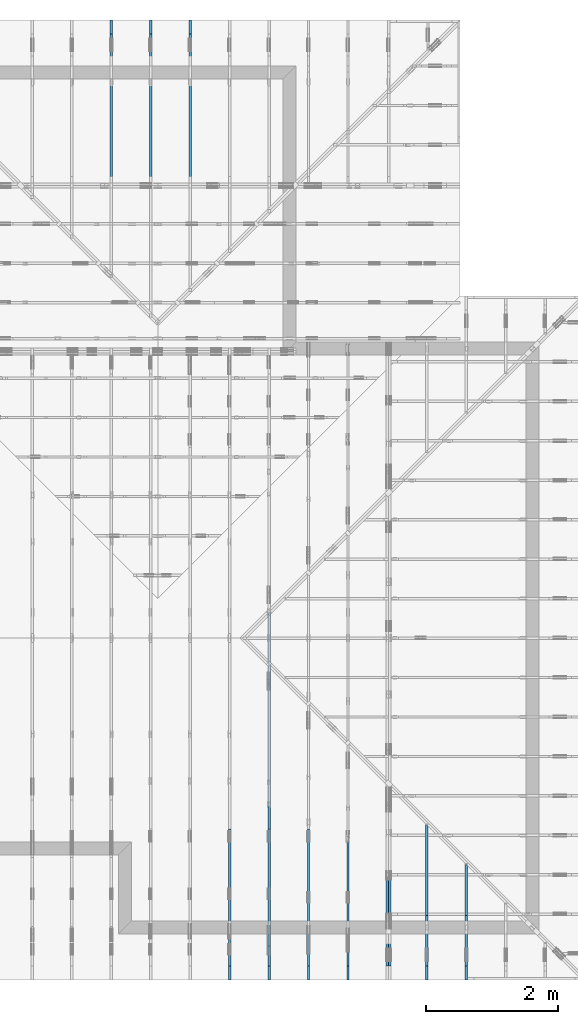
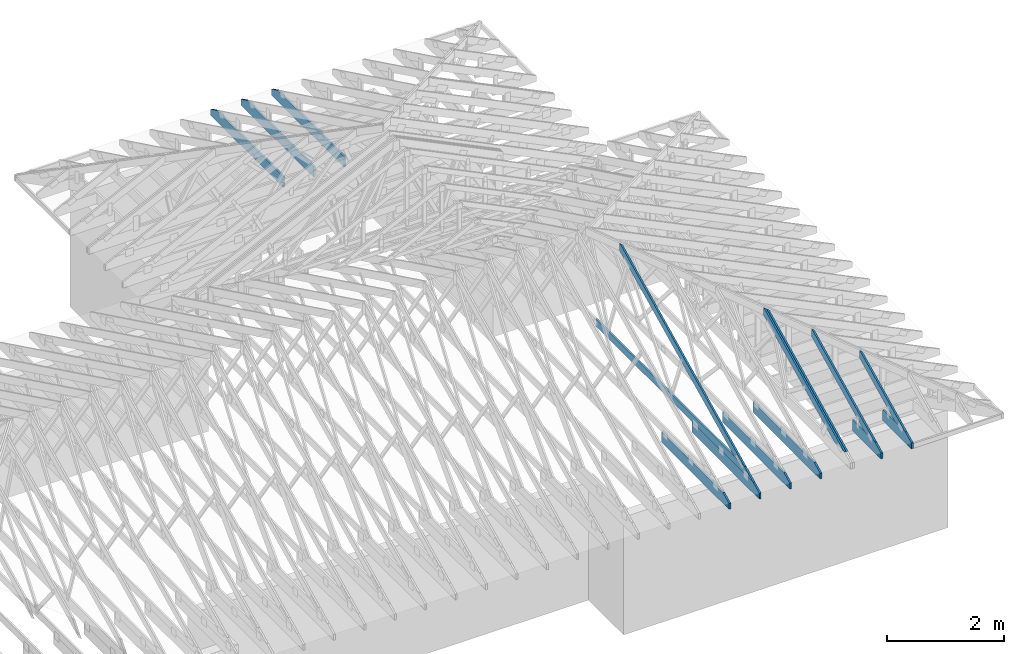
# One storey, part 28 of 159: 15 members, 10 elements without a shape of their own.
"""IFC2X3 building model written with IfcOpenShell, lengths in millimetres."""

from ifc_helpers import new_model, si_unit, frame, origin, origin_with_axes, origin_2d, place, context, project, spatial, faceted_brep, element, aggregate, save


model = new_model("IFC2X3")

# Units and contexts
model_context = context("Model", 3, precision=1e-05, world=origin())
plan_context = context("Plan", 2, precision=1e-05, world=origin_2d())
ifc_project = project(units=[si_unit("LENGTHUNIT", "METRE", prefix="MILLI"), si_unit("AREAUNIT", "SQUARE_METRE"), si_unit("VOLUMEUNIT", "CUBIC_METRE"), si_unit("SOLIDANGLEUNIT", "STERADIAN"), si_unit("PLANEANGLEUNIT", "RADIAN"), si_unit("MASSUNIT", "GRAM"), si_unit("TIMEUNIT", "SECOND"), si_unit("THERMODYNAMICTEMPERATUREUNIT", "DEGREE_CELSIUS"), si_unit("LUMINOUSINTENSITYUNIT", "LUMEN")], contexts=[model_context, plan_context])

# Site, building, storey
site_placement = place(None, origin_with_axes())
site = spatial("IfcSite", under=ifc_project, at=site_placement, CompositionType="ELEMENT")
building_placement = place(site_placement, origin_with_axes())
building = spatial("IfcBuilding", under=site, at=building_placement, Name="Plan 1", CompositionType="ELEMENT")
storey_placement = place(building_placement, origin_with_axes())
storey = spatial("IfcBuildingStorey", under=building, at=storey_placement, Name="Etasje 1", CompositionType="ELEMENT", Elevation=0.0)

# Assembly, members
assembly_1_placement = place(storey_placement, frame((16311.022261404749, -699.9989301294839, 1.1021457184401395e-15), z_axis=(1.0, -6.123031769111886e-17, 6.123031769111886e-17), x_axis=(6.123031769111886e-17, 1.0, 0.0)))
assembly_1 = element("IfcElementAssembly", 1, at=assembly_1_placement, inside=storey, Name="V8 (33)", AssemblyPlace="FACTORY", PredefinedType="TRUSS")
member_1_placement = place(assembly_1_placement, frame((579.5050728037174, 237.97842169881216, -36.00000021823818), z_axis=(0.0, 0.0, 1.0), x_axis=(0.898794046299167, 0.4383711467890774, 0.0)))
member_1 = element("IfcMember", 2, at=member_1_placement, Name="V8-O12", context=model_context, shape_type="Brep", body=[
    faceted_brep([(4739.075193296503, 148.00000083133853, 2.2545041247212794e-06), (4699.021526299754, 147.99999513754904, 35.999997189202986), (4626.837102349728, 3.20328240377421e-07, 36.000000218238256), (4666.890772291672, -1.1368683772161603e-13, 0.0), (4.108212567643932e-05, 148.00000031960755, 2.1823817775157297e-07), (4.108212567643932e-05, 148.00000031960664, 36.00000021823817), (4699.021525457127, 148.00000031960636, 36.00000021823817), (4739.075194432957, 148.00000031960727, 2.1823817775157297e-07), (303.4451035090831, 3.2085522150282486e-07, 2.1823817775157295e-07), (303.4451035090831, 3.2085522150282486e-07, 36.00000021823818), (0.00013179595180190518, 148.00000186179548, 36.00000021823818), (0.00013179595180190518, 148.00000186179548, 2.1823817775157295e-07), (4666.890772205104, 3.203226003585549e-07, 2.1823817775157297e-07), (4626.837103229274, 3.2032260992034295e-07, 36.00000021823818), (303.4449714238542, 3.203234040883642e-07, 36.00000021823818), (303.4449714238542, 3.2032340188407275e-07, 2.1823817775157297e-07), (4699.021527703733, 148.00000032032858, 36.00000021823818), (0.00018828722863872827, 148.00000032032858, 36.00000021823818), (303.4450125059782, 3.208556336176116e-07, 36.00000021823818), (4626.837102349728, 3.208556336176116e-07, 36.00000021823818), (0.0, 148.00000032018724, 2.1823817775157295e-07), (4739.075195312501, 148.00000032018724, 2.182387581017325e-07), (4666.890769958497, 3.196018951712176e-07, 2.182387492619819e-07), (303.4453125000002, 3.196018951712176e-07, 2.1823821491167872e-07)], [[[0, 1, 2, 3]], [[4, 5, 6, 7]], [[8, 9, 10, 11]], [[12, 13, 14, 15]], [[16, 17, 18, 19]], [[20, 21, 22, 23]]]),
])
member_2_placement = place(assembly_1_placement, frame((5591.181295681745, 371.0000000000015, -36.0), z_axis=(0.0, 0.0, 1.0), x_axis=(-1.0, 1.2246063538223773e-16, 0.0)))
member_2 = element("IfcMember", 3, at=member_2_placement, Name="V8-U32", context=model_context, shape_type="Brep", body=[
    faceted_brep([(5380.000006008893, 148.00000000000213, 36.0), (0.00014333799481391907, 148.00000000000213, 36.0), (0.00014333799481391907, 1.4779288903810084e-12, 36.0), (5076.555013943464, 1.4779288903810084e-12, 36.0), (0.00014333799481391907, 148.00000000000213, 1.7553261919328425e-20), (5380.000006008893, 148.00000000000213, 6.588382190922919e-13), (5076.555013943464, 1.4779288903810084e-12, 6.216781525604012e-13), (0.00014333799481391907, 1.4779288903810084e-12, 1.7553261919328425e-20), (0.0, 0.0, 0.0), (2.204291436880279e-15, -2.6993892992798474e-31, 36.0), (2.032846547345146e-14, 147.99999999999997, 36.0), (1.812417403657118e-14, 147.99999999999997, -1.1097489341483815e-30), (5076.555031444877, -9.325172320554534e-13, 1.8587832840457288e-28), (5076.555031444877, -9.30312940618573e-13, 36.0), (4.049083948919771e-31, 2.204291436880279e-15, 36.0), (0.0, 0.0, 0.0), (5380.000000000002, 148.00000000000318, -2.524354896707238e-29), (5380.000000000002, 148.00000000000318, 36.0), (5076.555031444877, 2.5011104298755527e-12, 36.0), (5076.555031444877, 2.5011104298755527e-12, -2.524354896707238e-29), (0.0, 147.99999999999997, 0.0), (0.0, 147.99999999999997, 36.0), (5380.0, 148.00000000000202, 36.0), (5380.0, 148.00000000000202, -6.310887241768095e-30)], [[[0, 1, 2, 3]], [[4, 5, 6, 7]], [[8, 9, 10, 11]], [[12, 13, 14, 15]], [[16, 17, 18, 19]], [[20, 21, 22, 23]]]),
])
member_3_placement = place(assembly_1_placement, frame((2300.0, 223.0, -36.0), z_axis=(0.0, 0.0, 1.0), x_axis=(-1.0, 1.2246063538223773e-16, 0.0)))
member_3 = element("IfcMember", 4, at=member_3_placement, Name="V8-U14", context=model_context, shape_type="Brep", body=[
    faceted_brep([(2300.0, 223.0, 36.0), (0.0, 223.0, 36.0), (0.0, 0.0, 36.0), (2088.8187103271484, 0.0, 36.0), (2299.999971237703, 102.99998474121122, 36.0), (0.0, 223.0, 0.0), (2300.0, 223.0, 2.8165946137914677e-13), (2299.999971237703, 102.99998474121122, 2.816594578568976e-13), (2088.8187103271484, 2.5579538487363607e-13, 2.5579806646496897e-13), (0.0, 2.5579538487363607e-13, 0.0), (2088.818704318255, -3.836970985936741e-13, 3.915632792378598e-29), (2088.818704318255, -3.8149280715679385e-13, 36.0), (4.049083948919771e-31, 2.204291436880279e-15, 36.0), (0.0, 0.0, 0.0), (2299.9999712377034, 102.9999859716911, -1.262177448353619e-29), (2299.9999712377034, 102.9999859716911, 36.0), (2088.818704318255, 2.2737367544323206e-13, 36.0), (2088.818704318255, 2.2737367544323206e-13, -6.310887241768095e-30), (2299.99994654994, 223.00000000000028, -3.2727641506682196e-21), (2299.99994654994, 223.00000000000028, 36.0), (2299.99994654994, 102.99998597169105, 36.0), (2299.99994654994, 102.99998597169105, -1.511639601365707e-21), (0.0, 223.0, 0.0), (0.0, 223.0, 36.0), (2300.0, 223.00000000000037, 36.0), (2300.0, 223.00000000000037, 4.733165431326071e-30), (0.0, 0.0, 0.0), (2.204291436880279e-15, -2.6993892992798474e-31, 36.0), (2.951301312711929e-14, 223.0, 36.0), (2.7308721690239013e-14, 223.0, -1.6721217048316832e-30)], [[[0, 1, 2, 3, 4]], [[5, 6, 7, 8, 9]], [[10, 11, 12, 13]], [[14, 15, 16, 17]], [[18, 19, 20, 21]], [[22, 23, 24, 25]], [[26, 27, 28, 29]]]),
])
aggregate(assembly_1, [member_1, member_2, member_3])

assembly_2_placement = place(storey_placement, frame((18074.541652722903, -699.9989301294845, 4.408582873760558e-15), z_axis=(-1.0, 1.836909530733566e-16, 6.123031769111886e-17), x_axis=(-1.836909530733566e-16, -1.0, 0.0)))
assembly_2 = element("IfcElementAssembly", 5, at=assembly_2_placement, inside=storey, Name="V5 (30)", AssemblyPlace="FACTORY", PredefinedType="TRUSS")
member_4_placement = place(assembly_2_placement, frame((-3039.4382525335886, 1437.7679977890675, -36.00000021758881), z_axis=(0.0, 0.0, 1.0), x_axis=(0.8987940462991668, -0.4383711467890778, 0.0)))
member_4 = element("IfcMember", 6, at=member_4_placement, Name="V5-O36.1", context=model_context, shape_type="Brep", body=[
    faceted_brep([(112.23809094841113, 1.031634205617138e-06, 2.253334827173603e-06), (72.18442395107833, 6.724569804106295e-06, 35.999997187384), (-2.842170943040401e-14, 148.0000015412774, 36.00000021758879), (40.053669942527904, 148.00000186245978, -2.842170943040401e-14), (2771.094823498021, 1.5419981276164957e-06, 2.1758881274536182e-07), (2771.094823498021, 1.5419983616353546e-06, 36.00000021758881), (72.18442310739556, 1.5419988574007785e-06, 36.00000021758881), (112.23809208322609, 1.5419986160244228e-06, 2.1758881274536182e-07), (40.05366761051073, 148.00000154196886, 2.175888176503594e-07), (3074.539850777015, 148.00000154196886, 2.1758918925546543e-07), (2771.09478241764, 1.5399751305267273e-06, 2.1758915209538954e-07), (112.23809296451509, 1.5399751305267273e-06, 2.1758882649010997e-07), (8.812735359242651e-07, 148.00000154127287, 36.00000021758882), (3074.539753841479, 148.00000154127335, 36.00000021758882), (3074.539753841479, 148.00000154127335, 2.1758881274536177e-07), (40.05366985710407, 148.00000154127287, 2.1758881274536177e-07), (3074.5397544944285, 148.0000015409396, 2.175888127453618e-07), (3074.5397544944285, 148.0000015409396, 36.00000021758881), (2771.094782781297, -4.547473508864641e-13, 36.00000021758881), (2771.094782781297, -4.547473508864641e-13, 2.175888127453618e-07), (3074.539762745355, 148.00000153997533, 36.00000021758881), (5.937621426710393e-05, 148.00000153997533, 36.00000021758881), (72.18438554808927, 1.5419986425513343e-06, 36.00000021758881), (2771.0947859387143, 1.5419986425513343e-06, 36.00000021758881)], [[[0, 1, 2, 3]], [[4, 5, 6, 7]], [[8, 9, 10, 11]], [[12, 13, 14, 15]], [[16, 17, 18, 19]], [[20, 21, 22, 23]]]),
])
member_5_placement = place(assembly_2_placement, frame((-3003.438252533591, 1420.2096246006977, -72.0), z_axis=(0.0, 0.0, 1.0), x_axis=(0.8987940462991668, -0.4383711467890778, 0.0)))
member_5 = element("IfcMember", 7, at=member_5_placement, Name="V5-O36.1", context=model_context, shape_type="Brep", body=[
    faceted_brep([(112.23809296453233, 1.541938829063838e-06, -1.4210854715202004e-14), (72.18442302200447, 1.2207562463117938e-06, 36.00000021758841), (2.016125087322962e-06, 148.00000205158395, 35.999997964257574), (40.05366901345811, 147.9999963586485, 3.0302085747280216e-06), (8.812785381451248e-07, 148.00000154126877, 36.0), (3034.486042903984, 148.00000154126857, 36.0), (3034.486042903984, 148.0000015412688, 2.0194839173657902e-28), (40.05366985710908, 148.000001541269, 0.0), (3034.486083984375, 148.00000154094022, 36.0), (0.0, 148.00000154094022, 36.0), (72.1844253540039, 1.541273093152995e-06, 36.0), (2731.0410156249995, 1.541273093152995e-06, 36.0), (2731.041112560536, 1.5419683537325432e-06, -3.270625084474567e-27), (2731.041112560536, 1.5419681321158729e-06, 36.0), (72.18442310741102, 1.5419686205237922e-06, 36.0), (112.2380920832411, 1.541968834782966e-06, -1.3430515349218307e-28), (3034.4860846373244, 148.00000154093982, 2.926101739361503e-29), (3034.4860846373244, 148.00000154093982, 36.0), (2731.041112924193, -4.547473508864641e-13, 36.0), (2731.041112924193, -4.547473508864641e-13, 3.0301369202623844e-29), (40.05366761052892, 148.00000154193907, 4.904997584974327e-15), (3034.486139839533, 148.00000154193907, 3.7160510074334307e-13), (2731.041071480158, 1.5399752726352745e-06, 3.3444502486844744e-13), (112.23809296453237, 1.5399752726352745e-06, 1.37447481785273e-14)], [[[0, 1, 2, 3]], [[4, 5, 6, 7]], [[8, 9, 10, 11]], [[12, 13, 14, 15]], [[16, 17, 18, 19]], [[20, 21, 22, 23]]]),
])
aggregate(assembly_2, [member_4, member_5])

# Assembly, member
assembly_3_placement = place(storey_placement, frame((17475.02226140475, -699.9989301294827, 1.1021457184401395e-15), z_axis=(-1.0, 1.836909530733566e-16, 6.123031769111886e-17), x_axis=(-1.836909530733566e-16, -1.0, 0.0)))
assembly_3 = element("IfcElementAssembly", 8, at=assembly_3_placement, inside=storey, Name="V6 (31)", AssemblyPlace="FACTORY", PredefinedType="TRUSS")
member_6_placement = place(assembly_3_placement, frame((-2300.0010698705146, 0.0, -36.0), z_axis=(0.0, 0.0, 1.0), x_axis=(1.0, 0.0, 0.0)))
member_6 = element("IfcMember", 9, at=member_6_placement, Name="V6-U14", context=model_context, shape_type="Brep", body=[
    faceted_brep([(2088.8186968236396, 223.0, 36.0), (9.330801458418136e-05, 223.0, 36.0), (9.330801458418136e-05, 0.0, 36.0), (2299.99999999997, 0.0, 36.0), (2299.999971237702, 120.00001525878906, 36.0), (9.330801458418136e-05, 223.0, 1.1426558752233954e-20), (2088.8186968236396, 223.0, 2.5579806481132067e-13), (2299.999971237702, 120.00001525878906, 2.8165945785689747e-13), (2299.99999999997, 0.0, 2.816594613791431e-13), (9.330801458418136e-05, 0.0, 1.1426558752233954e-20), (2088.8187043173357, 223.00000000000034, 2.524354896707238e-29), (2088.8187043173357, 223.00000000000034, 36.0), (2299.999971237707, 120.00001402830958, 36.0), (2299.999971237707, 120.00001402830958, 2.524354896707238e-29), (0.0, 223.0, 0.0), (-1.3496946496399237e-31, 223.0, 36.0), (2088.818704317335, 222.99999999999986, 36.0), (2088.818704317335, 222.99999999999986, -7.888609052210118e-30), (0.0, 0.0, 0.0), (2.204291436880279e-15, -2.6993892992798474e-31, 36.0), (2.951301312711929e-14, 223.0, 36.0), (2.7308721690239013e-14, 223.0, -1.6721217048316832e-30), (2300.0, -4.2248919206872015e-13, 2.586914745143187e-29), (2300.0, -4.202849006318399e-13, 36.0), (4.049083948919771e-31, 2.204291436880279e-15, 36.0), (0.0, 0.0, 0.0), (2299.999999999868, 120.00001402830924, 1.7611162946620003e-21), (2299.999999999868, 120.00001402830924, 36.0), (2299.999999999868, 0.0, 36.0), (2299.999999999868, 0.0, -8.077935669463161e-27)], [[[0, 1, 2, 3, 4]], [[5, 6, 7, 8, 9]], [[10, 11, 12, 13]], [[14, 15, 16, 17]], [[18, 19, 20, 21]], [[22, 23, 24, 25]], [[26, 27, 28, 29]]]),
])
aggregate(assembly_3, [member_6])

assembly_4_placement = place(storey_placement, frame((16875.02226140475, -699.9989301294827, 1.1021457184401395e-15), z_axis=(-1.0, 1.836909530733566e-16, 6.123031769111886e-17), x_axis=(-1.836909530733566e-16, -1.0, 0.0)))
assembly_4 = element("IfcElementAssembly", 10, at=assembly_4_placement, inside=storey, Name="V7 (32)", AssemblyPlace="FACTORY", PredefinedType="TRUSS")
member_7_placement = place(assembly_4_placement, frame((-2300.0010698705146, 0.0, -36.0), z_axis=(0.0, 0.0, 1.0), x_axis=(1.0, 0.0, 0.0)))
member_7 = element("IfcMember", 11, at=member_7_placement, Name="V7-U14", context=model_context, shape_type="Brep", body=[
    faceted_brep([(2088.8186968236396, 223.0, 36.0), (9.330801458418136e-05, 223.0, 36.0), (9.330801458418136e-05, 0.0, 36.0), (2299.99999999997, 0.0, 36.0), (2299.999971237702, 120.00001525878906, 36.0), (9.330801458418136e-05, 223.0, 1.1426558752233954e-20), (2088.8186968236396, 223.0, 2.5579806481132067e-13), (2299.999971237702, 120.00001525878906, 2.8165945785689747e-13), (2299.99999999997, 0.0, 2.816594613791431e-13), (9.330801458418136e-05, 0.0, 1.1426558752233954e-20), (2088.8187043173357, 223.00000000000034, 2.524354896707238e-29), (2088.8187043173357, 223.00000000000034, 36.0), (2299.999971237707, 120.00001402830958, 36.0), (2299.999971237707, 120.00001402830958, 2.524354896707238e-29), (0.0, 223.0, 0.0), (-1.3496946496399237e-31, 223.0, 36.0), (2088.818704317335, 222.99999999999986, 36.0), (2088.818704317335, 222.99999999999986, -7.888609052210118e-30), (0.0, 0.0, 0.0), (2.204291436880279e-15, -2.6993892992798474e-31, 36.0), (2.951301312711929e-14, 223.0, 36.0), (2.7308721690239013e-14, 223.0, -1.6721217048316832e-30), (2300.0, -4.2248919206872015e-13, 2.586914745143187e-29), (2300.0, -4.202849006318399e-13, 36.0), (4.049083948919771e-31, 2.204291436880279e-15, 36.0), (0.0, 0.0, 0.0), (2299.999999999868, 120.00001402830924, 1.7611162946620003e-21), (2299.999999999868, 120.00001402830924, 36.0), (2299.999999999868, 0.0, 36.0), (2299.999999999868, 0.0, -8.077935669463161e-27)], [[[0, 1, 2, 3, 4]], [[5, 6, 7, 8, 9]], [[10, 11, 12, 13]], [[14, 15, 16, 17]], [[18, 19, 20, 21]], [[22, 23, 24, 25]], [[26, 27, 28, 29]]]),
])
aggregate(assembly_4, [member_7])

# Assembly, members
assembly_5_placement = place(storey_placement, frame((19311.02226140475, -699.9989301294839, 1.1021457184401395e-15), z_axis=(1.0, -6.123031769111886e-17, 6.123031769111886e-17), x_axis=(6.123031769111886e-17, 1.0, 0.0)))
assembly_5 = element("IfcElementAssembly", 12, at=assembly_5_placement, inside=storey, Name="S23 (53)", AssemblyPlace="FACTORY", PredefinedType="TRUSS")
member_8_placement = place(assembly_5_placement, frame((276.0601837435577, 89.97846046921362, -36.000000217484704), z_axis=(0.0, 0.0, 1.0), x_axis=(0.898794046299167, 0.4383711467890774, 0.0)))
member_8 = element("IfcMember", 13, at=member_8_placement, Name="S23-O60", context=model_context, shape_type="Brep", body=[
    faceted_brep([(1738.8827442689753, 148.0000008307485, 2.253192519674485e-06), (1698.829077271549, 147.99999513793597, 35.999997187137865), (1626.6446533203125, 3.213054355910572e-07, 36.00000021748451), (1666.6983232629336, 0.0, -2.2737367544323206e-13), (9.693554090972611e-05, 148.00000032062542, 2.1748470402371822e-07), (9.693554090972611e-05, 148.00000032062553, 36.000000217484704), (1698.8290764277288, 148.00000032062542, 36.000000217484704), (1738.8827454035586, 148.0000003206253, 2.1748470402371822e-07), (303.44501506700624, 3.2091308810322516e-07, 2.1748470402371822e-07), (303.44501506700624, 3.2091308810322516e-07, 36.000000217484704), (4.33538749078366e-05, 148.00000186185335, 36.000000217484704), (4.33538749078366e-05, 148.00000186185335, 2.1748470402371822e-07), (1666.698323177667, 3.213170444562616e-07, 2.1748470402371822e-07), (1626.6446542018366, 3.2131705401804967e-07, 36.000000217484704), (303.4450272792291, 3.213172970778502e-07, 36.000000217484704), (303.4450272792291, 3.213172948735588e-07, 2.1748470402371822e-07), (1698.8290786743164, 148.00000032130538, 36.000000217484704), (0.0, 148.00000032130538, 36.000000217484704), (303.44506835937517, 3.209132160009176e-07, 36.000000217484704), (1626.644653320313, 3.209132160009176e-07, 36.000000217484704), (5.5855374739621766e-05, 148.00000032187774, 2.1748470402372505e-07), (1738.8827462850625, 148.00000032187774, 2.174849169684042e-07), (1666.6983209310586, 3.2059597288025543e-07, 2.1748490812865359e-07), (303.4450021444374, 3.2059597288025543e-07, 2.1748474118378598e-07)], [[[0, 1, 2, 3]], [[4, 5, 6, 7]], [[8, 9, 10, 11]], [[12, 13, 14, 15]], [[16, 17, 18, 19]], [[20, 21, 22, 23]]]),
])
member_9_placement = place(assembly_5_placement, frame((982.00634765625, 223.00000000000057, -36.0), z_axis=(0.0, 0.0, 1.0), x_axis=(-1.0, -7.657177843178875e-16, 0.0)))
member_9 = element("IfcMember", 14, at=member_9_placement, Name="S23-U21", context=model_context, shape_type="Brep", body=[
    faceted_brep([(982.0063476562502, 223.00000000001438, 36.0), (2.2737367544323206e-13, 223.00000000001438, 36.0), (0.0, 5.684341886080801e-13, 36.0), (770.8250579833984, 5.684341886080801e-13, 36.0), (982.0063188939531, 102.99998474121077, 36.0), (2.2737367544323206e-13, 223.00000000001438, 2.78443247639729e-29), (982.0063476562502, 223.00000000001438, 1.2025712128337504e-13), (982.0063188939531, 102.99998474121077, 1.2025711776112586e-13), (770.8250579833984, 5.684341886080801e-13, 9.439572636919721e-14), (0.0, 5.684341886080801e-13, 0.0), (1.6105506801977754e-05, 5.684341886080801e-13, 0.0), (1.6105506804182045e-05, 5.684341886080801e-13, 36.0), (1.6105507029554554e-05, 223.00000000000057, 36.0), (1.6105507027350263e-05, 223.00000000000057, 1.225320264969462e-31), (770.8250519745052, -2.5778956449313753e-13, 1.5784536931369985e-29), (770.8250519745052, -2.5558527305625725e-13, 36.0), (1.6105506801977754e-05, 5.706384746587427e-13, 36.0), (1.6105506801977754e-05, 5.684341832218624e-13, 3.2979982550020796e-37), (982.0063188939536, 102.99998597132787, -6.310887241768095e-30), (982.0063188939536, 102.99998597132787, 36.0), (770.8250519745051, 5.684341886080802e-14, 36.0), (770.8250519745051, 5.684341886080802e-14, -3.1554436208840472e-30), (982.0062942062657, 223.00000000001438, -3.2727595310987586e-21), (982.0062942062657, 223.00000000001438, 36.0), (982.0062942062657, 102.99998597132782, 36.0), (982.0062942062657, 102.99998597132782, -1.5116349817962461e-21), (1.610550702935143e-05, 223.00000000000057, 0.0), (1.610550702935143e-05, 223.00000000000057, 36.0), (982.0063476562502, 223.00000000001447, 36.0), (982.0063476562502, 223.00000000001447, 4.733165431326071e-30)], [[[0, 1, 2, 3, 4]], [[5, 6, 7, 8, 9]], [[10, 11, 12, 13]], [[14, 15, 16, 17]], [[18, 19, 20, 21]], [[22, 23, 24, 25]], [[26, 27, 28, 29]]]),
])
aggregate(assembly_5, [member_8, member_9])

assembly_6_placement = place(storey_placement, frame((18711.02226140475, -699.9989301294839, 1.1021457184401395e-15), z_axis=(1.0, -6.123031769111886e-17, 6.123031769111886e-17), x_axis=(6.123031769111886e-17, 1.0, 0.0)))
assembly_6 = element("IfcElementAssembly", 15, at=assembly_6_placement, inside=storey, Name="S24 (52)", AssemblyPlace="FACTORY", PredefinedType="TRUSS")
member_10_placement = place(assembly_6_placement, frame((276.0601900877647, 89.9784635646889, -36.00000021745184), z_axis=(0.0, 0.0, 1.0), x_axis=(0.8987940462991669, 0.43837114678907757, 0.0)))
member_10 = element("IfcMember", 16, at=member_10_placement, Name="S24-O50", context=model_context, shape_type="Brep", body=[
    faceted_brep([(2406.4439014956356, 148.00000083071518, 2.2530907699547242e-06), (2366.3902344981802, 147.99999513796047, 35.99999718700292), (2294.205810546875, 3.2136335903487634e-07, 36.00000021745211), (2334.259480489526, 1.1368683772161603e-13, 0.0), (9.693473379002171e-05, 148.00000031902846, 2.1745184142218932e-07), (9.693473379002171e-05, 148.00000031902846, 36.00000021745184), (2366.390233653484, 148.00000031902832, 36.00000021745184), (2406.443902629314, 148.00000031902832, 2.1745184142218932e-07), (303.44500800790365, 3.19835649520428e-07, 2.1745184142218932e-07), (303.44500800790365, 3.19835649520428e-07, 36.00000021745184), (3.629476771038753e-05, 148.0000018607662, 36.00000021745184), (3.629476771038753e-05, 148.0000018607662, 2.1745184142218932e-07), (2334.259480404349, 3.2139357734885777e-07, 2.1745184142218932e-07), (2294.2058114285187, 3.2139358691064584e-07, 36.00000021745184), (303.4450272793489, 3.213939525953916e-07, 36.00000021745184), (303.4450272793489, 3.213939503911002e-07, 2.1745184142218932e-07), (2366.390235900879, 148.00000032136347, 36.00000021745184), (0.0, 148.00000032136347, 36.00000021745184), (303.4450683593749, 3.1983563530957326e-07, 36.00000021745184), (2294.205810546875, 3.1983563530957326e-07, 36.00000021745184), (5.585467800983679e-05, 148.00000032080007, 2.1745184142219615e-07), (2406.443903510928, 148.00000032080007, 2.1745213611683874e-07), (2334.259478156924, 3.1899833174975356e-07, 2.1745212727708816e-07), (303.44512421405307, 3.1899833174975356e-07, 2.1745187858227204e-07)], [[[0, 1, 2, 3]], [[4, 5, 6, 7]], [[8, 9, 10, 11]], [[12, 13, 14, 15]], [[16, 17, 18, 19]], [[20, 21, 22, 23]]]),
])
member_11_placement = place(assembly_6_placement, frame((982.00634765625, 223.00000000000057, -36.0), z_axis=(0.0, 0.0, 1.0), x_axis=(-1.0, -7.657177843178875e-16, 0.0)))
member_11 = element("IfcMember", 17, at=member_11_placement, Name="S24-U21", context=model_context, shape_type="Brep", body=[
    faceted_brep([(982.0063476562502, 223.00000000001438, 36.0), (2.2737367544323206e-13, 223.00000000001438, 36.0), (0.0, 5.684341886080801e-13, 36.0), (770.8250579833984, 5.684341886080801e-13, 36.0), (982.0063188939531, 102.99998474121077, 36.0), (2.2737367544323206e-13, 223.00000000001438, 2.78443247639729e-29), (982.0063476562502, 223.00000000001438, 1.2025712128337504e-13), (982.0063188939531, 102.99998474121077, 1.2025711776112586e-13), (770.8250579833984, 5.684341886080801e-13, 9.439572636919721e-14), (0.0, 5.684341886080801e-13, 0.0), (1.6105506801977754e-05, 5.684341886080801e-13, 0.0), (1.6105506804182045e-05, 5.684341886080801e-13, 36.0), (1.6105507029554554e-05, 223.00000000000057, 36.0), (1.6105507027350263e-05, 223.00000000000057, 1.225320264969462e-31), (770.8250519745052, -2.5778956449313753e-13, 1.5784536931369985e-29), (770.8250519745052, -2.5558527305625725e-13, 36.0), (1.6105506801977754e-05, 5.706384746587427e-13, 36.0), (1.6105506801977754e-05, 5.684341832218624e-13, 3.2979982550020796e-37), (982.0063188939536, 102.99998597132787, -6.310887241768095e-30), (982.0063188939536, 102.99998597132787, 36.0), (770.8250519745051, 5.684341886080802e-14, 36.0), (770.8250519745051, 5.684341886080802e-14, -3.1554436208840472e-30), (982.0062942062657, 223.00000000001438, -3.2727595310987586e-21), (982.0062942062657, 223.00000000001438, 36.0), (982.0062942062657, 102.99998597132782, 36.0), (982.0062942062657, 102.99998597132782, -1.5116349817962461e-21), (1.610550702935143e-05, 223.00000000000057, 0.0), (1.610550702935143e-05, 223.00000000000057, 36.0), (982.0063476562502, 223.00000000001447, 36.0), (982.0063476562502, 223.00000000001447, 4.733165431326071e-30)], [[[0, 1, 2, 3, 4]], [[5, 6, 7, 8, 9]], [[10, 11, 12, 13]], [[14, 15, 16, 17]], [[18, 19, 20, 21]], [[22, 23, 24, 25]], [[26, 27, 28, 29]]]),
])
aggregate(assembly_6, [member_10, member_11])

# Assembly, member
assembly_7_placement = place(storey_placement, frame((15075.022261404756, 13899.999978540158, 1.1021457184401395e-15), z_axis=(-1.0, 1.836909530733566e-16, 6.123031769111886e-17), x_axis=(-1.836909530733566e-16, -1.0, 0.0)))
assembly_7 = element("IfcElementAssembly", 18, at=assembly_7_placement, inside=storey, Name="S37 (66)", AssemblyPlace="FACTORY", PredefinedType="TRUSS")
member_12_placement = place(assembly_7_placement, frame((2482.0, 223.00000000093004, -36.0), z_axis=(0.0, 0.0, 1.0), x_axis=(-1.0, 5.665498452323003e-16, 0.0)))
member_12 = element("IfcMember", 19, at=member_12_placement, Name="S37-U12", context=model_context, shape_type="Brep", body=[
    faceted_brep([(2482.0, 223.00000000093144, 36.0), (0.0, 223.00000000093144, 36.0), (0.0, 9.300435976911103e-10, 36.0), (2270.8187103271484, 9.300435976911103e-10, 36.0), (2482.0, 103.00000000093144, 36.0), (0.0, 223.00000000093144, 0.0), (2482.0, 223.00000000093144, 3.0394729701871404e-13), (2482.0, 103.00000000093144, 3.0394729701871404e-13), (2270.8187103271484, 9.300435976911103e-10, 2.7808590210453623e-13), (0.0, 9.300435976911103e-10, 0.0), (1.1389372990643566e-25, 9.300435976911103e-10, -6.97374926519754e-42), (2.204291436994173e-15, 9.300435976911103e-10, 36.0), (2.9513013127233185e-14, 223.00000000093004, 36.0), (2.7308721690352905e-14, 223.00000000093004, -1.672121704838657e-30), (2270.8187043163925, -1.6082071276856806e-13, 9.847103334126301e-30), (2270.8187043163925, -1.5861642133168778e-13, 36.0), (9.029525915557911e-28, 9.300458019825472e-10, 36.0), (0.0, 9.300435976911103e-10, 0.0), (2482.0000000000005, 103.00000000087255, 4.487866375234114e-29), (2482.0000000000005, 103.00000000087255, 36.0), (2270.8187043163925, -6.821210263296962e-13, 36.0), (2270.8187043163925, -6.821210263296962e-13, 3.1532860652502367e-29), (2482.0, 223.00000000093144, 0.0), (2482.0, 223.00000000093144, 36.0), (2482.0, 103.00000000087323, 36.0), (2482.0, 103.00000000087323, 0.0), (0.0, 223.00000000093004, 0.0), (0.0, 223.00000000093004, 36.0), (2482.0, 223.0000000009321, 36.0), (2482.0, 223.0000000009321, 4.1020767071492614e-29)], [[[0, 1, 2, 3, 4]], [[5, 6, 7, 8, 9]], [[10, 11, 12, 13]], [[14, 15, 16, 17]], [[18, 19, 20, 21]], [[22, 23, 24, 25]], [[26, 27, 28, 29]]]),
])
aggregate(assembly_7, [member_12])

assembly_8_placement = place(storey_placement, frame((14475.022261404756, 13899.999978540158, 1.1021457184401395e-15), z_axis=(-1.0, 1.836909530733566e-16, 6.123031769111886e-17), x_axis=(-1.836909530733566e-16, -1.0, 0.0)))
assembly_8 = element("IfcElementAssembly", 20, at=assembly_8_placement, inside=storey, Name="S36 (68)", AssemblyPlace="FACTORY", PredefinedType="TRUSS")
member_13_placement = place(assembly_8_placement, frame((2482.0, 223.00000000093004, -36.0), z_axis=(0.0, 0.0, 1.0), x_axis=(-1.0, 5.665498452323003e-16, 0.0)))
member_13 = element("IfcMember", 21, at=member_13_placement, Name="S36-U12", context=model_context, shape_type="Brep", body=[
    faceted_brep([(2482.0, 223.00000000093144, 36.0), (0.0, 223.00000000093144, 36.0), (0.0, 9.300435976911103e-10, 36.0), (2270.8187103271484, 9.300435976911103e-10, 36.0), (2482.000000000002, 103.00000000093144, 36.0), (0.0, 223.00000000093144, 0.0), (2482.0, 223.00000000093144, 3.0394729701871404e-13), (2482.000000000002, 103.00000000093144, 3.0394729701871424e-13), (2270.8187103271484, 9.300435976911103e-10, 2.7808590210453623e-13), (0.0, 9.300435976911103e-10, 0.0), (3.637978807091827e-12, 9.300435976911103e-10, -6.995281933909487e-42), (3.640183098528707e-12, 9.300435976911103e-10, 36.0), (3.667491820218946e-12, 223.00000000093004, 36.0), (3.665287528782066e-12, 223.00000000093004, -1.6721217048386785e-30), (2270.8187043163925, -1.608207127671205e-13, 9.847103334034466e-30), (2270.8187043163925, -1.5861642133024021e-13, 36.0), (3.637978807091714e-12, 9.300458019825472e-10, 36.0), (3.637978807091713e-12, 9.300435976911103e-10, 0.0), (2482.0000000000023, 103.00000000074328, -4.34737576324108e-29), (2482.0000000000023, 103.00000000074328, 36.0), (2270.8187043163925, 6.821210263296962e-13, 36.0), (2270.8187043163925, 6.821210263296962e-13, -3.157601176517703e-29), (2482.000000000003, 223.00000000093144, 2.0194839173657902e-28), (2482.000000000003, 223.00000000093144, 36.0), (2482.000000000003, 103.00000000074226, 36.0), (2482.000000000003, 103.00000000074226, 1.0097419586828951e-28), (3.637978807091713e-12, 223.00000000093004, 0.0), (3.637978807091713e-12, 223.00000000093004, 36.0), (2482.0, 223.0000000009321, 36.0), (2482.0, 223.0000000009321, 4.1020767071492614e-29)], [[[0, 1, 2, 3, 4]], [[5, 6, 7, 8, 9]], [[10, 11, 12, 13]], [[14, 15, 16, 17]], [[18, 19, 20, 21]], [[22, 23, 24, 25]], [[26, 27, 28, 29]]]),
])
aggregate(assembly_8, [member_13])

assembly_9_placement = place(storey_placement, frame((13875.022261404758, 13899.999978540158, 1.1021457184401395e-15), z_axis=(-1.0, 1.836909530733566e-16, 6.123031769111886e-17), x_axis=(-1.836909530733566e-16, -1.0, 0.0)))
assembly_9 = element("IfcElementAssembly", 22, at=assembly_9_placement, inside=storey, Name="S35 (73)", AssemblyPlace="FACTORY", PredefinedType="TRUSS")
member_14_placement = place(assembly_9_placement, frame((2482.0, 223.00000000093104, -36.0), z_axis=(0.0, 0.0, 1.0), x_axis=(-1.0, 1.2246063538223773e-16, 0.0)))
member_14 = element("IfcMember", 23, at=member_14_placement, Name="S35-U12", context=model_context, shape_type="Brep", body=[
    faceted_brep([(2482.0, 223.00000000093135, 36.0), (0.0, 223.00000000093135, 36.0), (0.0, 9.310383575211745e-10, 36.0), (2270.8187103271484, 9.310383575211745e-10, 36.0), (2482.000000000002, 103.00000000093135, 36.0), (0.0, 223.00000000093135, 0.0), (2482.0, 223.00000000093135, 3.0394729701871404e-13), (2482.000000000002, 103.00000000093135, 3.0394729701871424e-13), (2270.8187103271484, 9.310383575211745e-10, 2.7808590210453623e-13), (0.0, 9.310383575211745e-10, 0.0), (1.8189894035459704e-12, 9.310383575211745e-10, -6.97286115848029e-42), (1.8211936949828507e-12, 9.310383575211745e-10, 36.0), (1.8485024166730897e-12, 223.00000000093104, 36.0), (1.8462981252362094e-12, 223.00000000093104, -1.672121704838656e-30), (2270.8187043163925, 8.33939117296296e-13, -5.106235708711034e-29), (2270.8187043163925, 8.361434087331763e-13, 36.0), (1.8189894035458573e-12, 9.310405618126114e-10, 36.0), (1.8189894035458565e-12, 9.310383575211745e-10, 0.0), (2482.000000000001, 103.00000000074351, -9.396085556655556e-29), (2482.000000000001, 103.00000000074351, 36.0), (2270.818704316392, 1.2505552149377763e-12, 36.0), (2270.818704316392, 1.2505552149377763e-12, -8.206310969932178e-29), (2482.000000000003, 223.00000000093135, 2.0194839173657902e-28), (2482.000000000003, 223.00000000093135, 36.0), (2482.000000000003, 103.00000000074218, 36.0), (2482.000000000003, 103.00000000074218, 1.0097419586828951e-28), (1.818989403545857e-12, 223.00000000093104, 0.0), (1.818989403545857e-12, 223.00000000093104, 36.0), (2482.0, 223.00000000093144, 36.0), (2482.0, 223.00000000093144, 4.733165431326071e-30)], [[[0, 1, 2, 3, 4]], [[5, 6, 7, 8, 9]], [[10, 11, 12, 13]], [[14, 15, 16, 17]], [[18, 19, 20, 21]], [[22, 23, 24, 25]], [[26, 27, 28, 29]]]),
])
aggregate(assembly_9, [member_14])

assembly_10_placement = place(storey_placement, frame((15675.02226140475, -699.9989301294845, 1.1021457184401395e-15), z_axis=(-1.0, 1.836909530733566e-16, 6.123031769111886e-17), x_axis=(-1.836909530733566e-16, -1.0, 0.0)))
assembly_10 = element("IfcElementAssembly", 24, at=assembly_10_placement, inside=storey, Name="T7 (111)", AssemblyPlace="FACTORY", PredefinedType="TRUSS")
member_15_placement = place(assembly_10_placement, frame((-2299.9990234375, 0.0, -36.0), z_axis=(0.0, 0.0, 1.0), x_axis=(1.0, 0.0, 0.0)))
member_15 = element("IfcMember", 25, at=member_15_placement, Name="T7-U14", context=model_context, shape_type="Brep", body=[
    faceted_brep([(2088.8177337646484, 223.0, 36.0), (0.0, 223.0, 36.0), (0.0, 0.0, 36.0), (2300.0000933080446, 0.0, 36.0), (2300.0000933080446, 119.99948120117188, 36.0), (0.0, 223.0, 0.0), (2088.8177337646484, 223.0, 2.5579794687450473e-13), (2300.0000933080446, 119.99948120117188, 2.816594728057092e-13), (2300.0000933080446, 0.0, 2.816594728057092e-13), (0.0, 0.0, 0.0), (2088.8177277548316, 223.00000000000023, 2.524354896707238e-29), (2088.8177277548316, 223.00000000000023, 36.0), (2300.0000933080146, 119.99947818928456, 36.0), (2300.0000933080146, 119.99947818928456, 2.524354896707238e-29), (9.330801458418136e-05, 223.0, 0.0), (9.330801458418136e-05, 223.0, 36.0), (2088.817727754831, 222.99999999999986, 36.0), (2088.817727754831, 222.99999999999986, -7.888609052210118e-30), (9.330801458418136e-05, 0.0, 0.0), (9.330801458638566e-05, -2.6993892992798474e-31, 36.0), (9.330801461369438e-05, 223.0, 36.0), (9.330801461149009e-05, 223.0, -1.6721217180559947e-30), (2300.0000933080146, -4.2248920920855827e-13, 2.5869148500909603e-29), (2300.0000933080146, -4.20284917771678e-13, 36.0), (9.330801458418136e-05, 2.204274297042151e-15, 36.0), (9.330801458418136e-05, -1.713983812835093e-20, 1.0494777337732796e-36), (2300.0000933080146, 119.99947818928416, 0.0), (2300.0000933080146, 119.99947818928416, 36.0), (2300.0000933080146, 0.0, 36.0), (2300.0000933080146, 0.0, 0.0)], [[[0, 1, 2, 3, 4]], [[5, 6, 7, 8, 9]], [[10, 11, 12, 13]], [[14, 15, 16, 17]], [[18, 19, 20, 21]], [[22, 23, 24, 25]], [[26, 27, 28, 29]]]),
])
aggregate(assembly_10, [member_15])

save(model, "model.ifc")
